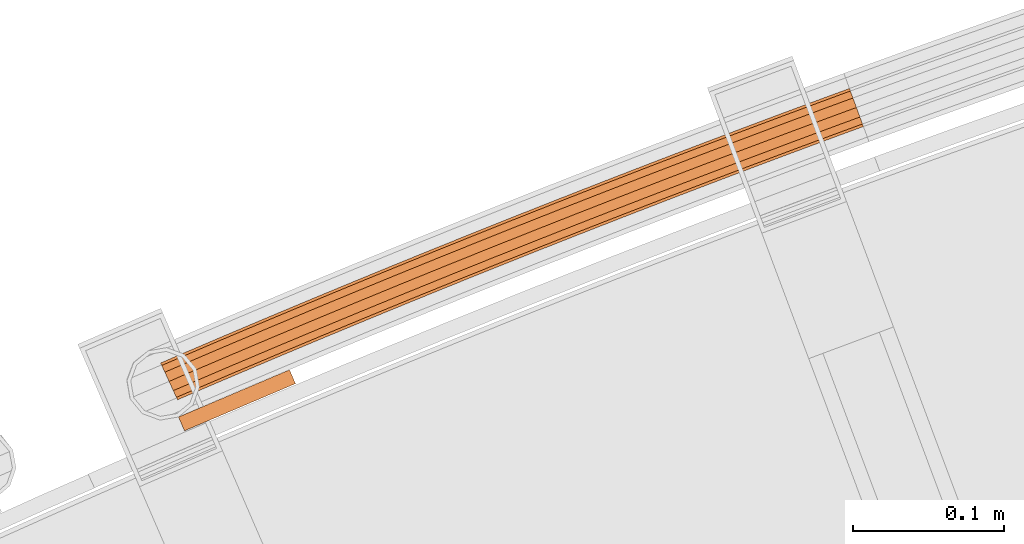
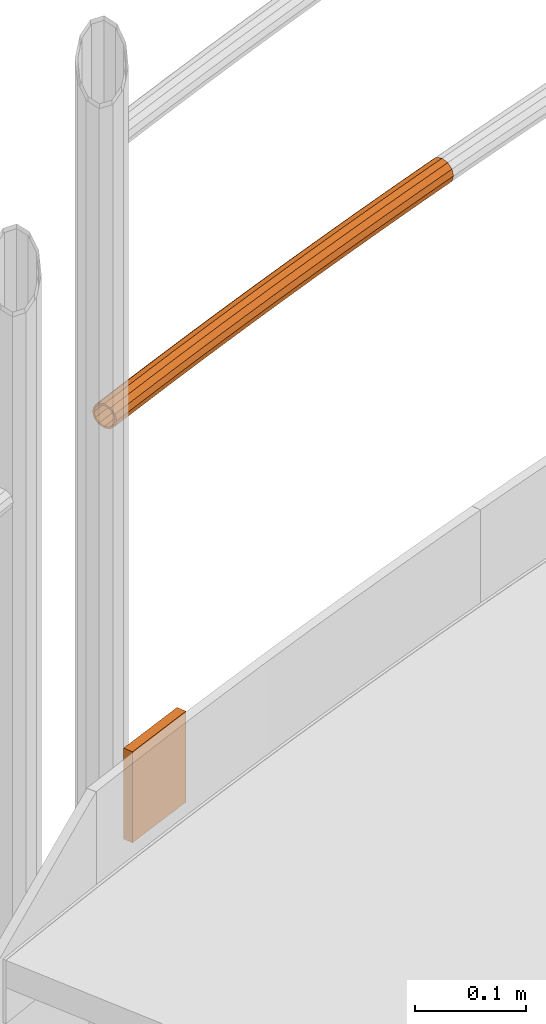
# One storey, part 101 of 126: 2 proxies.
"""IFC2X3 building model written with IfcOpenShell, lengths in millimetres."""

from ifc_helpers import new_model, si_unit, origin, origin_with_axes, place, context, project, spatial, faceted_brep, material, element, save


model = new_model("IFC2X3")

# Units and contexts
context_of_model_1 = context(None, 3, precision=0.1, world=origin())
context_of_model_2 = context(None, 3, precision=0.1, world=origin())
ifc_project = project(units=[si_unit("LENGTHUNIT", "METRE", prefix="MILLI"), si_unit("AREAUNIT", "SQUARE_METRE", prefix="CENTI"), si_unit("VOLUMEUNIT", "CUBIC_METRE", prefix="CENTI"), si_unit("MASSUNIT", "GRAM", prefix="KILO")], contexts=[context_of_model_1, context_of_model_2])

# Site, building, storey
site_placement = place(None, origin_with_axes())
site = spatial("IfcSite", under=ifc_project, at=site_placement, CompositionType="ELEMENT")
building_placement = place(site_placement, origin_with_axes())
building = spatial("IfcBuilding", under=site, at=building_placement, CompositionType="ELEMENT")
storey_placement = place(building_placement, origin_with_axes())
storey = spatial("IfcBuildingStorey", under=building, at=storey_placement, CompositionType="ELEMENT")

# Proxies
ifc_material = material(Name="S235JRG2")
proxy_1_placement = place(storey_placement, origin_with_axes())
element("IfcBuildingElementProxy", 1, at=proxy_1_placement, inside=storey, material=ifc_material, context=context_of_model_2, shape_type="Brep", body=[
    faceted_brep([(4502.0995, 16162.147, 11538.155), (4502.8105, 16160.491, 11531.43), (4492.1373, 16155.886, 11531.43), (4491.383, 16157.523, 11538.155), (4504.753, 16155.968, 11526.507), (4494.1982, 16151.413, 11526.507), (4507.4066, 16149.788, 11524.705), (4497.0135, 16145.304, 11524.705), (4510.0602, 16143.609, 11526.507), (4499.8288, 16139.194, 11526.507), (4512.0027, 16139.085, 11531.43), (4501.8897, 16134.722, 11531.43), (4512.7138, 16137.43, 11538.155), (4502.644, 16133.085, 11538.155), (4512.0027, 16139.085, 11544.88), (4501.8897, 16134.722, 11544.88), (4510.0602, 16143.609, 11549.803), (4499.8288, 16139.194, 11549.803), (4507.4066, 16149.788, 11551.605), (4497.0135, 16145.304, 11551.605), (4504.753, 16155.968, 11549.803), (4494.1982, 16151.413, 11549.803), (4502.8105, 16160.491, 11544.88), (4492.1373, 16155.886, 11544.88), (4502.8886, 16160.309, 11538.155), (4503.4939, 16158.9, 11543.88), (4492.8624, 16154.312, 11543.88), (4492.2202, 16155.706, 11538.155), (4505.1476, 16155.049, 11548.071), (4494.6169, 16150.505, 11548.071), (4507.4066, 16149.788, 11549.605), (4497.0135, 16145.304, 11549.605), (4509.6656, 16144.528, 11548.071), (4499.4101, 16140.103, 11548.071), (4511.3193, 16140.677, 11543.88), (4501.1646, 16136.295, 11543.88), (4511.9246, 16139.267, 11538.155), (4501.8068, 16134.902, 11538.155), (4511.3193, 16140.677, 11532.43), (4501.1646, 16136.295, 11532.43), (4509.6656, 16144.528, 11528.239), (4499.4101, 16140.103, 11528.239), (4507.4066, 16149.788, 11526.705), (4497.0135, 16145.304, 11526.705), (4505.1476, 16155.049, 11528.239), (4494.6169, 16150.505, 11528.239), (4503.4939, 16158.9, 11532.43), (4492.8624, 16154.312, 11532.43), (4530.5945, 16174.325, 11538.155), (4531.2998, 16172.666, 11531.43), (4533.2265, 16168.136, 11526.507), (4535.8585, 16161.948, 11524.705), (4538.4905, 16155.759, 11526.507), (4540.4173, 16151.229, 11531.43), (4541.1225, 16149.57, 11538.155), (4540.4173, 16151.229, 11544.88), (4538.4905, 16155.759, 11549.803), (4535.8585, 16161.948, 11551.605), (4533.2265, 16168.136, 11549.803), (4531.2998, 16172.666, 11544.88), (4531.3773, 16172.484, 11538.155), (4531.9777, 16171.073, 11543.88), (4533.6179, 16167.216, 11548.071), (4535.8585, 16161.948, 11549.605), (4538.0992, 16156.679, 11548.071), (4539.7394, 16152.823, 11543.88), (4540.3398, 16151.411, 11538.155), (4539.7394, 16152.823, 11532.43), (4538.0992, 16156.679, 11528.239), (4535.8585, 16161.948, 11526.705), (4533.6179, 16167.216, 11528.239), (4531.9777, 16171.073, 11532.43), (4559.132, 16186.403, 11538.155), (4559.8314, 16184.742, 11531.43), (4561.7424, 16180.205, 11526.507), (4564.3527, 16174.007, 11524.705), (4566.9631, 16167.81, 11526.507), (4568.874, 16163.273, 11531.43), (4569.5735, 16161.612, 11538.155), (4568.874, 16163.273, 11544.88), (4566.9631, 16167.81, 11549.803), (4564.3527, 16174.007, 11551.605), (4561.7424, 16180.205, 11549.803), (4559.8314, 16184.742, 11544.88), (4559.9083, 16184.56, 11538.155), (4560.5037, 16183.146, 11543.88), (4562.1305, 16179.284, 11548.071), (4564.3527, 16174.007, 11549.605), (4566.5749, 16168.731, 11548.071), (4568.2017, 16164.869, 11543.88), (4568.7972, 16163.455, 11538.155), (4568.2017, 16164.869, 11532.43), (4566.5749, 16168.731, 11528.239), (4564.3527, 16174.007, 11526.705), (4562.1305, 16179.284, 11528.239), (4560.5037, 16183.146, 11532.43), (4587.7114, 16198.381, 11538.155), (4588.405, 16196.718, 11531.43), (4590.3001, 16192.174, 11526.507), (4592.8888, 16185.968, 11524.705), (4595.4776, 16179.761, 11526.507), (4597.3726, 16175.217, 11531.43), (4598.0663, 16173.554, 11538.155), (4597.3726, 16175.217, 11544.88), (4595.4776, 16179.761, 11549.803), (4592.8888, 16185.968, 11551.605), (4590.3001, 16192.174, 11549.803), (4588.405, 16196.718, 11544.88), (4588.4813, 16196.535, 11538.155), (4589.0718, 16195.12, 11543.88), (4590.6851, 16191.252, 11548.071), (4592.8888, 16185.968, 11549.605), (4595.0926, 16180.684, 11548.071), (4596.7059, 16176.816, 11543.88), (4597.2964, 16175.4, 11538.155), (4596.7059, 16176.816, 11532.43), (4595.0926, 16180.684, 11528.239), (4592.8888, 16185.968, 11526.705), (4590.6851, 16191.252, 11528.239), (4589.0718, 16195.12, 11532.43), (4616.3325, 16210.26, 11538.155), (4617.0203, 16208.594, 11531.43), (4618.8995, 16204.044, 11526.507), (4621.4665, 16197.828, 11524.705), (4624.0336, 16191.613, 11526.507), (4625.9128, 16187.062, 11531.43), (4626.6006, 16185.397, 11538.155), (4625.9128, 16187.062, 11544.88), (4624.0336, 16191.613, 11549.803), (4621.4665, 16197.828, 11551.605), (4618.8995, 16204.044, 11549.803), (4617.0203, 16208.594, 11544.88), (4617.0959, 16208.411, 11538.155), (4617.6814, 16206.994, 11543.88), (4619.2812, 16203.12, 11548.071), (4621.4665, 16197.828, 11549.605), (4623.6519, 16192.537, 11548.071), (4625.2516, 16188.663, 11543.88), (4625.8372, 16187.245, 11538.155), (4625.2516, 16188.663, 11532.43), (4623.6519, 16192.537, 11528.239), (4621.4665, 16197.828, 11526.705), (4619.2812, 16203.12, 11528.239), (4617.6814, 16206.994, 11532.43), (4644.9948, 16222.039, 11538.155), (4645.6768, 16220.371, 11531.43), (4647.5401, 16215.814, 11526.507), (4650.0855, 16209.589, 11524.705), (4652.6308, 16203.365, 11526.507), (4654.4941, 16198.808, 11531.43), (4655.1761, 16197.14, 11538.155), (4654.4941, 16198.808, 11544.88), (4652.6308, 16203.365, 11549.803), (4650.0855, 16209.589, 11551.605), (4647.5401, 16215.814, 11549.803), (4645.6768, 16220.371, 11544.88), (4645.7518, 16220.187, 11538.155), (4646.3324, 16218.768, 11543.88), (4647.9186, 16214.888, 11548.071), (4650.0855, 16209.589, 11549.605), (4652.2523, 16204.29, 11548.071), (4653.8385, 16200.411, 11543.88), (4654.4191, 16198.991, 11538.155), (4653.8385, 16200.411, 11532.43), (4652.2523, 16204.29, 11528.239), (4650.0855, 16209.589, 11526.705), (4647.9186, 16214.888, 11528.239), (4646.3324, 16218.768, 11532.43), (4673.6981, 16233.717, 11538.155), (4674.3743, 16232.047, 11531.43), (4676.2217, 16227.484, 11526.507), (4678.7453, 16221.25, 11524.705), (4681.2688, 16215.017, 11526.507), (4683.1162, 16210.453, 11531.43), (4683.7924, 16208.783, 11538.155), (4683.1162, 16210.453, 11544.88), (4681.2688, 16215.017, 11549.803), (4678.7453, 16221.25, 11551.605), (4676.2217, 16227.484, 11549.803), (4674.3743, 16232.047, 11544.88), (4674.4486, 16231.863, 11538.155), (4675.0242, 16230.441, 11543.88), (4676.5969, 16226.557, 11548.071), (4678.7453, 16221.25, 11549.605), (4680.8936, 16215.943, 11548.071), (4682.4663, 16212.059, 11543.88), (4683.0419, 16210.637, 11538.155), (4682.4663, 16212.059, 11532.43), (4680.8936, 16215.943, 11528.239), (4678.7453, 16221.25, 11526.705), (4676.5969, 16226.557, 11528.239), (4675.0242, 16230.441, 11532.43), (4702.442, 16245.295, 11538.155), (4703.1123, 16243.623, 11531.43), (4704.9438, 16239.053, 11526.507), (4707.4456, 16232.811, 11524.705), (4709.9474, 16226.568, 11526.507), (4711.7789, 16221.999, 11531.43), (4712.4492, 16220.326, 11538.155), (4711.7789, 16221.999, 11544.88), (4709.9474, 16226.568, 11549.803), (4707.4456, 16232.811, 11551.605), (4704.9438, 16239.053, 11549.803), (4703.1123, 16243.623, 11544.88), (4703.186, 16243.439, 11538.155), (4703.7567, 16242.015, 11543.88), (4705.3158, 16238.125, 11548.071), (4707.4456, 16232.811, 11549.605), (4709.5754, 16227.497, 11548.071), (4711.1345, 16223.607, 11543.88), (4711.7052, 16222.183, 11538.155), (4711.1345, 16223.607, 11532.43), (4709.5754, 16227.497, 11528.239), (4707.4456, 16232.811, 11526.705), (4705.3158, 16238.125, 11528.239), (4703.7567, 16242.015, 11532.43), (4731.2261, 16256.773, 11538.155), (4731.8906, 16255.098, 11531.43), (4733.7061, 16250.522, 11526.507), (4736.1861, 16244.271, 11524.705), (4738.6661, 16238.02, 11526.507), (4740.4816, 16233.444, 11531.43), (4741.1461, 16231.769, 11538.155), (4740.4816, 16233.444, 11544.88), (4738.6661, 16238.02, 11549.803), (4736.1861, 16244.271, 11551.605), (4733.7061, 16250.522, 11549.803), (4731.8906, 16255.098, 11544.88), (4731.9636, 16254.914, 11538.155), (4732.5293, 16253.488, 11543.88), (4734.0749, 16249.593, 11548.071), (4736.1861, 16244.271, 11549.605), (4738.2973, 16238.95, 11548.071), (4739.8429, 16235.054, 11543.88), (4740.4086, 16233.628, 11538.155), (4739.8429, 16235.054, 11532.43), (4738.2973, 16238.95, 11528.239), (4736.1861, 16244.271, 11526.705), (4734.0749, 16249.593, 11528.239), (4732.5293, 16253.488, 11532.43), (4760.0501, 16268.151, 11538.155), (4760.7088, 16266.473, 11531.43), (4762.5083, 16261.891, 11526.507), (4764.9664, 16255.631, 11524.705), (4767.4246, 16249.372, 11526.507), (4769.2241, 16244.789, 11531.43), (4769.8828, 16243.112, 11538.155), (4769.2241, 16244.789, 11544.88), (4767.4246, 16249.372, 11549.803), (4764.9664, 16255.631, 11551.605), (4762.5083, 16261.891, 11549.803), (4760.7088, 16266.473, 11544.88), (4760.7812, 16266.289, 11538.155), (4761.3419, 16264.861, 11543.88), (4762.8738, 16260.96, 11548.071), (4764.9664, 16255.631, 11549.605), (4767.0591, 16250.303, 11548.071), (4768.591, 16246.402, 11543.88), (4769.1517, 16244.974, 11538.155), (4768.591, 16246.402, 11532.43), (4767.0591, 16250.303, 11528.239), (4764.9664, 16255.631, 11526.705), (4762.8738, 16260.96, 11528.239), (4761.3419, 16264.861, 11532.43), (4788.9136, 16279.427, 11538.155), (4789.5665, 16277.748, 11531.43), (4791.35, 16273.159, 11526.507), (4793.7863, 16266.891, 11524.705), (4796.2226, 16260.623, 11526.507), (4798.0061, 16256.034, 11531.43), (4798.6589, 16254.354, 11538.155), (4798.0061, 16256.034, 11544.88), (4796.2226, 16260.623, 11549.803), (4793.7863, 16266.891, 11551.605), (4791.35, 16273.159, 11549.803), (4789.5665, 16277.748, 11544.88), (4789.6382, 16277.563, 11538.155), (4790.1939, 16276.133, 11543.88), (4791.7122, 16272.227, 11548.071), (4793.7863, 16266.891, 11549.605), (4795.8603, 16261.555, 11548.071), (4797.3786, 16257.648, 11543.88), (4797.9343, 16256.219, 11538.155), (4797.3786, 16257.648, 11532.43), (4795.8603, 16261.555, 11528.239), (4793.7863, 16266.891, 11526.705), (4791.7122, 16272.227, 11528.239), (4790.1939, 16276.133, 11532.43), (4817.8164, 16290.603, 11538.155), (4818.4633, 16288.921, 11531.43), (4820.2308, 16284.326, 11526.507), (4822.6452, 16278.05, 11524.705), (4825.0596, 16271.773, 11526.507), (4826.8271, 16267.178, 11531.43), (4827.474, 16265.496, 11538.155), (4826.8271, 16267.178, 11544.88), (4825.0596, 16271.773, 11549.803), (4822.6452, 16278.05, 11551.605), (4820.2308, 16284.326, 11549.803), (4818.4633, 16288.921, 11544.88), (4818.5344, 16288.737, 11538.155), (4819.0852, 16287.305, 11543.88), (4820.5898, 16283.393, 11548.071), (4822.6452, 16278.05, 11549.605), (4824.7006, 16272.707, 11548.071), (4826.2052, 16268.795, 11543.88), (4826.756, 16267.363, 11538.155), (4826.2052, 16268.795, 11532.43), (4824.7006, 16272.707, 11528.239), (4822.6452, 16278.05, 11526.705), (4820.5898, 16283.393, 11528.239), (4819.0852, 16287.305, 11532.43), (4846.758, 16301.678, 11538.155), (4847.399, 16299.994, 11531.43), (4849.1504, 16295.393, 11526.507), (4851.5429, 16289.108, 11524.705), (4853.9354, 16282.823, 11526.507), (4855.6868, 16278.222, 11531.43), (4856.3279, 16276.538, 11538.155), (4855.6868, 16278.222, 11544.88), (4853.9354, 16282.823, 11549.803), (4851.5429, 16289.108, 11551.605), (4849.1504, 16295.393, 11549.803), (4847.399, 16299.994, 11544.88), (4847.4695, 16299.809, 11538.155), (4848.0152, 16298.375, 11543.88), (4849.5062, 16294.458, 11548.071), (4851.5429, 16289.108, 11549.605), (4853.5797, 16283.757, 11548.071), (4855.0706, 16279.841, 11543.88), (4855.6164, 16278.407, 11538.155), (4855.0706, 16279.841, 11532.43), (4853.5797, 16283.757, 11528.239), (4851.5429, 16289.108, 11526.705), (4849.5062, 16294.458, 11528.239), (4848.0152, 16298.375, 11532.43), (4875.738, 16312.652, 11538.155), (4876.3732, 16310.966, 11531.43), (4878.1085, 16306.358, 11526.507), (4880.4791, 16300.065, 11524.705), (4882.8496, 16293.772, 11526.507), (4884.585, 16289.165, 11531.43), (4885.2201, 16287.478, 11538.155), (4884.585, 16289.165, 11544.88), (4882.8496, 16293.772, 11549.803), (4880.4791, 16300.065, 11551.605), (4878.1085, 16306.358, 11549.803), (4876.3732, 16310.966, 11544.88), (4876.443, 16310.78, 11538.155), (4876.9837, 16309.345, 11543.88), (4878.461, 16305.423, 11548.071), (4880.4791, 16300.065, 11549.605), (4882.4971, 16294.708, 11548.071), (4883.9744, 16290.786, 11543.88), (4884.5151, 16289.35, 11538.155), (4883.9744, 16290.786, 11532.43), (4882.4971, 16294.708, 11528.239), (4880.4791, 16300.065, 11526.705), (4878.461, 16305.423, 11528.239), (4876.9837, 16309.345, 11532.43), (4904.7562, 16323.524, 11538.155), (4905.3855, 16321.836, 11531.43), (4907.1047, 16317.223, 11526.507), (4909.4533, 16310.921, 11524.705), (4911.8018, 16304.62, 11526.507), (4913.5211, 16300.007, 11531.43), (4914.1504, 16298.318, 11538.155), (4913.5211, 16300.007, 11544.88), (4911.8018, 16304.62, 11549.803), (4909.4533, 16310.921, 11551.605), (4907.1047, 16317.223, 11549.803), (4905.3855, 16321.836, 11544.88), (4905.4546, 16321.65, 11538.155), (4905.9904, 16320.213, 11543.88), (4907.454, 16316.286, 11548.071), (4909.4533, 16310.921, 11549.605), (4911.4526, 16305.557, 11548.071), (4912.9162, 16301.629, 11543.88), (4913.4519, 16300.192, 11538.155), (4912.9162, 16301.629, 11532.43), (4911.4526, 16305.557, 11528.239), (4909.4533, 16310.921, 11526.705), (4907.454, 16316.286, 11528.239), (4905.9904, 16320.213, 11532.43), (4933.8121, 16334.296, 11538.155), (4934.4355, 16332.605, 11531.43), (4936.1387, 16327.986, 11526.507), (4938.4652, 16321.676, 11524.705), (4940.7918, 16315.366, 11526.507), (4942.4949, 16310.747, 11531.43), (4943.1183, 16309.057, 11538.155), (4942.4949, 16310.747, 11544.88), (4940.7918, 16315.366, 11549.803), (4938.4652, 16321.676, 11551.605), (4936.1387, 16327.986, 11549.803), (4934.4355, 16332.605, 11544.88), (4934.504, 16332.419, 11538.155), (4935.0347, 16330.98, 11543.88), (4936.4846, 16327.048, 11548.071), (4938.4652, 16321.676, 11549.605), (4940.4458, 16316.305, 11548.071), (4941.8957, 16312.372, 11543.88), (4942.4264, 16310.933, 11538.155), (4941.8957, 16312.372, 11532.43), (4940.4458, 16316.305, 11528.239), (4938.4652, 16321.676, 11526.705), (4936.4846, 16327.048, 11528.239), (4935.0347, 16330.98, 11532.43), (4948.3572, 16339.63, 11538.155), (4948.9777, 16337.938, 11531.43), (4950.6729, 16333.316, 11526.507), (4952.9886, 16327.002, 11524.705), (4955.3043, 16320.689, 11526.507), (4956.9995, 16316.067, 11531.43), (4957.62, 16314.375, 11538.155), (4956.9995, 16316.067, 11544.88), (4955.3043, 16320.689, 11549.803), (4952.9886, 16327.002, 11551.605), (4950.6729, 16333.316, 11549.803), (4948.9777, 16337.938, 11544.88), (4949.0459, 16337.752, 11538.155), (4949.5741, 16336.312, 11543.88), (4951.0173, 16332.377, 11548.071), (4952.9886, 16327.002, 11549.605), (4954.96, 16321.627, 11548.071), (4956.4031, 16317.693, 11543.88), (4956.9313, 16316.253, 11538.155), (4956.4031, 16317.693, 11532.43), (4954.96, 16321.627, 11528.239), (4952.9886, 16327.002, 11526.705), (4951.0173, 16332.377, 11528.239), (4949.5741, 16336.312, 11532.43)], [[[0, 1, 2, 3]], [[1, 4, 5, 2]], [[4, 6, 7, 5]], [[6, 8, 9, 7]], [[8, 10, 11, 9]], [[10, 12, 13, 11]], [[12, 14, 15, 13]], [[14, 16, 17, 15]], [[16, 18, 19, 17]], [[18, 20, 21, 19]], [[20, 22, 23, 21]], [[0, 3, 23, 22]], [[24, 25, 26, 27]], [[25, 28, 29, 26]], [[28, 30, 31, 29]], [[30, 32, 33, 31]], [[32, 34, 35, 33]], [[34, 36, 37, 35]], [[36, 38, 39, 37]], [[38, 40, 41, 39]], [[40, 42, 43, 41]], [[42, 44, 45, 43]], [[44, 46, 47, 45]], [[24, 27, 47, 46]], [[0, 48, 49, 1]], [[1, 49, 50, 4]], [[4, 50, 51, 6]], [[6, 51, 52, 8]], [[8, 52, 53, 10]], [[10, 53, 54, 12]], [[12, 54, 55, 14]], [[14, 55, 56, 16]], [[16, 56, 57, 18]], [[18, 57, 58, 20]], [[20, 58, 59, 22]], [[22, 59, 48, 0]], [[24, 60, 61, 25]], [[25, 61, 62, 28]], [[28, 62, 63, 30]], [[30, 63, 64, 32]], [[32, 64, 65, 34]], [[34, 65, 66, 36]], [[36, 66, 67, 38]], [[38, 67, 68, 40]], [[40, 68, 69, 42]], [[42, 69, 70, 44]], [[44, 70, 71, 46]], [[46, 71, 60, 24]], [[48, 72, 73, 49]], [[49, 73, 74, 50]], [[50, 74, 75, 51]], [[51, 75, 76, 52]], [[52, 76, 77, 53]], [[53, 77, 78, 54]], [[54, 78, 79, 55]], [[55, 79, 80, 56]], [[56, 80, 81, 57]], [[57, 81, 82, 58]], [[58, 82, 83, 59]], [[59, 83, 72, 48]], [[60, 84, 85, 61]], [[61, 85, 86, 62]], [[62, 86, 87, 63]], [[63, 87, 88, 64]], [[64, 88, 89, 65]], [[65, 89, 90, 66]], [[66, 90, 91, 67]], [[67, 91, 92, 68]], [[68, 92, 93, 69]], [[69, 93, 94, 70]], [[70, 94, 95, 71]], [[71, 95, 84, 60]], [[72, 96, 97, 73]], [[73, 97, 98, 74]], [[74, 98, 99, 75]], [[75, 99, 100, 76]], [[76, 100, 101, 77]], [[77, 101, 102, 78]], [[78, 102, 103, 79]], [[79, 103, 104, 80]], [[80, 104, 105, 81]], [[81, 105, 106, 82]], [[82, 106, 107, 83]], [[83, 107, 96, 72]], [[84, 108, 109, 85]], [[85, 109, 110, 86]], [[86, 110, 111, 87]], [[87, 111, 112, 88]], [[88, 112, 113, 89]], [[89, 113, 114, 90]], [[90, 114, 115, 91]], [[91, 115, 116, 92]], [[92, 116, 117, 93]], [[93, 117, 118, 94]], [[94, 118, 119, 95]], [[95, 119, 108, 84]], [[96, 120, 121, 97]], [[97, 121, 122, 98]], [[98, 122, 123, 99]], [[99, 123, 124, 100]], [[100, 124, 125, 101]], [[101, 125, 126, 102]], [[102, 126, 127, 103]], [[103, 127, 128, 104]], [[104, 128, 129, 105]], [[105, 129, 130, 106]], [[106, 130, 131, 107]], [[107, 131, 120, 96]], [[108, 132, 133, 109]], [[109, 133, 134, 110]], [[110, 134, 135, 111]], [[111, 135, 136, 112]], [[112, 136, 137, 113]], [[113, 137, 138, 114]], [[114, 138, 139, 115]], [[115, 139, 140, 116]], [[116, 140, 141, 117]], [[117, 141, 142, 118]], [[118, 142, 143, 119]], [[119, 143, 132, 108]], [[120, 144, 145, 121]], [[121, 145, 146, 122]], [[122, 146, 147, 123]], [[123, 147, 148, 124]], [[124, 148, 149, 125]], [[125, 149, 150, 126]], [[126, 150, 151, 127]], [[127, 151, 152, 128]], [[128, 152, 153, 129]], [[129, 153, 154, 130]], [[130, 154, 155, 131]], [[131, 155, 144, 120]], [[132, 156, 157, 133]], [[133, 157, 158, 134]], [[134, 158, 159, 135]], [[135, 159, 160, 136]], [[136, 160, 161, 137]], [[137, 161, 162, 138]], [[138, 162, 163, 139]], [[139, 163, 164, 140]], [[140, 164, 165, 141]], [[141, 165, 166, 142]], [[142, 166, 167, 143]], [[143, 167, 156, 132]], [[144, 168, 169, 145]], [[145, 169, 170, 146]], [[146, 170, 171, 147]], [[147, 171, 172, 148]], [[148, 172, 173, 149]], [[149, 173, 174, 150]], [[150, 174, 175, 151]], [[151, 175, 176, 152]], [[152, 176, 177, 153]], [[153, 177, 178, 154]], [[154, 178, 179, 155]], [[155, 179, 168, 144]], [[156, 180, 181, 157]], [[157, 181, 182, 158]], [[158, 182, 183, 159]], [[159, 183, 184, 160]], [[160, 184, 185, 161]], [[161, 185, 186, 162]], [[162, 186, 187, 163]], [[163, 187, 188, 164]], [[164, 188, 189, 165]], [[165, 189, 190, 166]], [[166, 190, 191, 167]], [[167, 191, 180, 156]], [[168, 192, 193, 169]], [[169, 193, 194, 170]], [[170, 194, 195, 171]], [[171, 195, 196, 172]], [[172, 196, 197, 173]], [[173, 197, 198, 174]], [[174, 198, 199, 175]], [[175, 199, 200, 176]], [[176, 200, 201, 177]], [[177, 201, 202, 178]], [[178, 202, 203, 179]], [[179, 203, 192, 168]], [[180, 204, 205, 181]], [[181, 205, 206, 182]], [[182, 206, 207, 183]], [[183, 207, 208, 184]], [[184, 208, 209, 185]], [[185, 209, 210, 186]], [[186, 210, 211, 187]], [[187, 211, 212, 188]], [[188, 212, 213, 189]], [[189, 213, 214, 190]], [[190, 214, 215, 191]], [[191, 215, 204, 180]], [[192, 216, 217, 193]], [[193, 217, 218, 194]], [[194, 218, 219, 195]], [[195, 219, 220, 196]], [[196, 220, 221, 197]], [[197, 221, 222, 198]], [[198, 222, 223, 199]], [[199, 223, 224, 200]], [[200, 224, 225, 201]], [[201, 225, 226, 202]], [[202, 226, 227, 203]], [[203, 227, 216, 192]], [[204, 228, 229, 205]], [[205, 229, 230, 206]], [[206, 230, 231, 207]], [[207, 231, 232, 208]], [[208, 232, 233, 209]], [[209, 233, 234, 210]], [[210, 234, 235, 211]], [[211, 235, 236, 212]], [[212, 236, 237, 213]], [[213, 237, 238, 214]], [[214, 238, 239, 215]], [[215, 239, 228, 204]], [[216, 240, 241, 217]], [[217, 241, 242, 218]], [[218, 242, 243, 219]], [[219, 243, 244, 220]], [[220, 244, 245, 221]], [[221, 245, 246, 222]], [[222, 246, 247, 223]], [[223, 247, 248, 224]], [[224, 248, 249, 225]], [[225, 249, 250, 226]], [[226, 250, 251, 227]], [[227, 251, 240, 216]], [[228, 252, 253, 229]], [[229, 253, 254, 230]], [[230, 254, 255, 231]], [[231, 255, 256, 232]], [[232, 256, 257, 233]], [[233, 257, 258, 234]], [[234, 258, 259, 235]], [[235, 259, 260, 236]], [[236, 260, 261, 237]], [[237, 261, 262, 238]], [[238, 262, 263, 239]], [[239, 263, 252, 228]], [[240, 264, 265, 241]], [[241, 265, 266, 242]], [[242, 266, 267, 243]], [[243, 267, 268, 244]], [[244, 268, 269, 245]], [[245, 269, 270, 246]], [[246, 270, 271, 247]], [[247, 271, 272, 248]], [[248, 272, 273, 249]], [[249, 273, 274, 250]], [[250, 274, 275, 251]], [[251, 275, 264, 240]], [[252, 276, 277, 253]], [[253, 277, 278, 254]], [[254, 278, 279, 255]], [[255, 279, 280, 256]], [[256, 280, 281, 257]], [[257, 281, 282, 258]], [[258, 282, 283, 259]], [[259, 283, 284, 260]], [[260, 284, 285, 261]], [[261, 285, 286, 262]], [[262, 286, 287, 263]], [[263, 287, 276, 252]], [[264, 288, 289, 265]], [[265, 289, 290, 266]], [[266, 290, 291, 267]], [[267, 291, 292, 268]], [[268, 292, 293, 269]], [[269, 293, 294, 270]], [[270, 294, 295, 271]], [[271, 295, 296, 272]], [[272, 296, 297, 273]], [[273, 297, 298, 274]], [[274, 298, 299, 275]], [[275, 299, 288, 264]], [[276, 300, 301, 277]], [[277, 301, 302, 278]], [[278, 302, 303, 279]], [[279, 303, 304, 280]], [[280, 304, 305, 281]], [[281, 305, 306, 282]], [[282, 306, 307, 283]], [[283, 307, 308, 284]], [[284, 308, 309, 285]], [[285, 309, 310, 286]], [[286, 310, 311, 287]], [[287, 311, 300, 276]], [[288, 312, 313, 289]], [[289, 313, 314, 290]], [[290, 314, 315, 291]], [[291, 315, 316, 292]], [[292, 316, 317, 293]], [[293, 317, 318, 294]], [[294, 318, 319, 295]], [[295, 319, 320, 296]], [[296, 320, 321, 297]], [[297, 321, 322, 298]], [[298, 322, 323, 299]], [[299, 323, 312, 288]], [[300, 324, 325, 301]], [[301, 325, 326, 302]], [[302, 326, 327, 303]], [[303, 327, 328, 304]], [[304, 328, 329, 305]], [[305, 329, 330, 306]], [[306, 330, 331, 307]], [[307, 331, 332, 308]], [[308, 332, 333, 309]], [[309, 333, 334, 310]], [[310, 334, 335, 311]], [[311, 335, 324, 300]], [[312, 336, 337, 313]], [[313, 337, 338, 314]], [[314, 338, 339, 315]], [[315, 339, 340, 316]], [[316, 340, 341, 317]], [[317, 341, 342, 318]], [[318, 342, 343, 319]], [[319, 343, 344, 320]], [[320, 344, 345, 321]], [[321, 345, 346, 322]], [[322, 346, 347, 323]], [[323, 347, 336, 312]], [[324, 348, 349, 325]], [[325, 349, 350, 326]], [[326, 350, 351, 327]], [[327, 351, 352, 328]], [[328, 352, 353, 329]], [[329, 353, 354, 330]], [[330, 354, 355, 331]], [[331, 355, 356, 332]], [[332, 356, 357, 333]], [[333, 357, 358, 334]], [[334, 358, 359, 335]], [[335, 359, 348, 324]], [[336, 360, 361, 337]], [[337, 361, 362, 338]], [[338, 362, 363, 339]], [[339, 363, 364, 340]], [[340, 364, 365, 341]], [[341, 365, 366, 342]], [[342, 366, 367, 343]], [[343, 367, 368, 344]], [[344, 368, 369, 345]], [[345, 369, 370, 346]], [[346, 370, 371, 347]], [[347, 371, 360, 336]], [[348, 372, 373, 349]], [[349, 373, 374, 350]], [[350, 374, 375, 351]], [[351, 375, 376, 352]], [[352, 376, 377, 353]], [[353, 377, 378, 354]], [[354, 378, 379, 355]], [[355, 379, 380, 356]], [[356, 380, 381, 357]], [[357, 381, 382, 358]], [[358, 382, 383, 359]], [[359, 383, 372, 348]], [[360, 384, 385, 361]], [[361, 385, 386, 362]], [[362, 386, 387, 363]], [[363, 387, 388, 364]], [[364, 388, 389, 365]], [[365, 389, 390, 366]], [[366, 390, 391, 367]], [[367, 391, 392, 368]], [[368, 392, 393, 369]], [[369, 393, 394, 370]], [[370, 394, 395, 371]], [[371, 395, 384, 360]], [[372, 396, 397, 373]], [[373, 397, 398, 374]], [[374, 398, 399, 375]], [[375, 399, 400, 376]], [[376, 400, 401, 377]], [[377, 401, 402, 378]], [[378, 402, 403, 379]], [[379, 403, 404, 380]], [[380, 404, 405, 381]], [[381, 405, 406, 382]], [[382, 406, 407, 383]], [[383, 407, 396, 372]], [[384, 408, 409, 385]], [[385, 409, 410, 386]], [[386, 410, 411, 387]], [[387, 411, 412, 388]], [[388, 412, 413, 389]], [[389, 413, 414, 390]], [[390, 414, 415, 391]], [[391, 415, 416, 392]], [[392, 416, 417, 393]], [[393, 417, 418, 394]], [[394, 418, 419, 395]], [[384, 395, 419, 408]], [[396, 420, 421, 397]], [[397, 421, 422, 398]], [[398, 422, 423, 399]], [[399, 423, 424, 400]], [[400, 424, 425, 401]], [[401, 425, 426, 402]], [[402, 426, 427, 403]], [[403, 427, 428, 404]], [[404, 428, 429, 405]], [[405, 429, 430, 406]], [[406, 430, 431, 407]], [[396, 407, 431, 420]], [[7, 9, 11, 13, 15, 17, 19, 21, 23, 3, 2, 5], [26, 29, 31, 33, 35, 37, 39, 41, 43, 45, 47, 27]], [[414, 413, 412, 411, 410, 409, 408, 419, 418, 417, 416, 415], [420, 431, 430, 429, 428, 427, 426, 425, 424, 423, 422, 421]]]),
])
proxy_2_placement = place(storey_placement, origin_with_axes())
element("IfcBuildingElementProxy", 2, at=proxy_2_placement, inside=storey, material=ifc_material, Name="HANDLAUF", context=context_of_model_2, shape_type="Brep", body=[
    faceted_brep([(4507.2197, 16112.522, 11085.15), (4503.3088, 16121.726, 11085.15), (4576.9366, 16153.013, 11085.15), (4580.8476, 16143.81, 11085.15), (4507.2197, 16112.522, 11185.15), (4580.8476, 16143.81, 11185.15), (4576.9366, 16153.013, 11185.15), (4503.3088, 16121.726, 11185.15)], [[[0, 1, 2, 3]], [[4, 5, 6, 7]], [[0, 4, 7, 1]], [[1, 7, 6, 2]], [[2, 6, 5, 3]], [[3, 5, 4, 0]]]),
])

save(model, "model.ifc")
